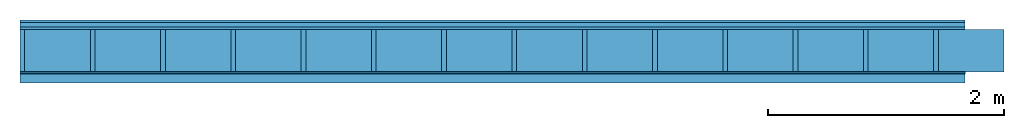
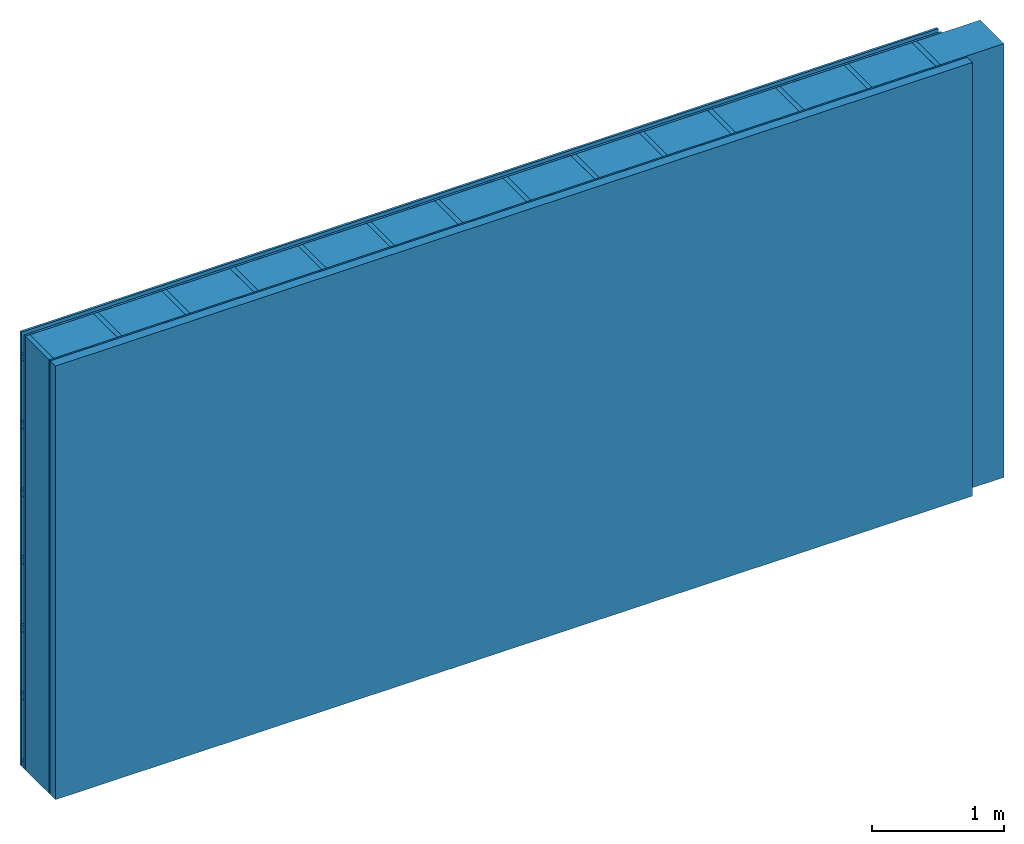
# One storey: 4 plates, 3 members, 1 element without a shape of its own.
"""IFC4 building model written with IfcOpenShell, lengths in metres."""

from ifc_helpers import new_model, si_unit, derived_unit, direction, frame, frame_2d, origin, origin_with_axes, place, context, project, spatial, rectangle, extrude, material, layer, layer_set, type_object, element, aggregate, save


model = new_model("IFC4")

# Units and contexts
plan_context = context("Plan", 3, precision=1e-05, world=origin(), true_north=direction((0.0, 1.0)))
model_context = context("Model", 3, precision=1e-05, world=origin(), true_north=direction((0.0, 1.0)))
ifc_project = project(units=[si_unit("LENGTHUNIT", "METRE"), derived_unit("SOUNDPRESSUREUNIT", [(si_unit("PRESSUREUNIT", "PASCAL", prefix="MICRO"), 0)]), si_unit("ENERGYUNIT", "JOULE", prefix="MEGA"), si_unit("MASSUNIT", "GRAM", prefix="KILO"), derived_unit("THERMALTRANSMITTANCEUNIT", [(si_unit("POWERUNIT", "WATT"), 1), (si_unit("AREAUNIT", "SQUARE_METRE"), -1), (si_unit("THERMODYNAMICTEMPERATUREUNIT", "KELVIN"), -1)]), derived_unit("AREADENSITYUNIT", [(si_unit("MASSUNIT", "GRAM", prefix="KILO"), 1), (si_unit("AREAUNIT", "SQUARE_METRE"), -1)]), derived_unit("USERDEFINED", [(si_unit("ENERGYUNIT", "JOULE", prefix="MEGA"), 1), (si_unit("AREAUNIT", "SQUARE_METRE"), -1)])], contexts=[plan_context, model_context])

# Site, building, storey
site = spatial("IfcSite", under=ifc_project)
building_placement = place(None, origin())
building = spatial("IfcBuilding", under=site, at=building_placement)
storey_placement = place(building_placement, origin())
storey = spatial("IfcBuildingStorey", under=building, at=storey_placement)

# Wall, members, plates
ifc_material_1 = material(Name="Wood cladding horizontal, closed")
ifc_layer_1 = layer(ifc_material_1, 0.02, Name="Cover 1st layer")
ifc_layer_2 = layer(None, 0.04, Name="Battens / profiles (ventilation)")
ifc_material_2 = material(Category="10.009")
ifc_layer_3 = layer(ifc_material_2, 0.02, Name="outside 1st layer")
ifc_material_3 = material(Name="of the art")
ifc_layer_4 = layer(ifc_material_3, 0.0, Name="Bond")
ifc_layer_5 = layer(None, 0.36, Name="Support")
ifc_layer_6 = layer(ifc_material_3, 0.0, Name="Bond")
ifc_material_4 = material(Name="OSB panel", Category="07.013")
ifc_layer_7 = layer(ifc_material_4, 0.015, Name="1st layer")
ifc_material_5 = material(Name="Solid timber panel")
ifc_layer_8 = layer(ifc_material_5, 0.08, Name="Covering 1st layer")
ifc_layer_set = layer_set([ifc_layer_1, ifc_layer_2, ifc_layer_3, ifc_layer_4, ifc_layer_5, ifc_layer_6, ifc_layer_7, ifc_layer_8])
wall_type = type_object("IfcWallType", Name="D0958", PredefinedType="NOTDEFINED", material=ifc_layer_set)
wall_placement = place(None, frame((0.0, 0.0, 0.0), z_axis=(0.0, -1.0, 0.0), x_axis=(1.0, 0.0, 0.0)))
wall = element("IfcWall", 1, at=wall_placement, inside=storey, type_object=wall_type, material=ifc_layer_set, Name="Wall #1")
ifc_material_6 = material()
member_1_placement = place(wall_placement, origin())
member_1 = element("IfcMember", 2, at=member_1_placement, material=ifc_material_6, Name="Battens / profiles (ventilation)", context=plan_context, shape_type="SweptSolid", body=[
    extrude(rectangle(XDim=0.06, YDim=0.04, at=frame_2d((0.03, 0.02), x_axis=(1.0, 0.0))), frame((0.0, 0.0, 0.02), z_axis=(1.0, 0.0, 0.0), x_axis=(0.0, 1.0, 0.0)), (0.0, 0.0, 1.0), 8.0),
    extrude(rectangle(XDim=0.06, YDim=0.04, at=frame_2d((0.03, 0.02), x_axis=(1.0, 0.0))), frame((0.0, 0.625, 0.02), z_axis=(1.0, 0.0, 0.0), x_axis=(0.0, 1.0, 0.0)), (0.0, 0.0, 1.0), 8.0),
    extrude(rectangle(XDim=0.06, YDim=0.04, at=frame_2d((0.03, 0.02), x_axis=(1.0, 0.0))), frame((0.0, 1.25, 0.02), z_axis=(1.0, 0.0, 0.0), x_axis=(0.0, 1.0, 0.0)), (0.0, 0.0, 1.0), 8.0),
    extrude(rectangle(XDim=0.06, YDim=0.04, at=frame_2d((0.03, 0.02), x_axis=(1.0, 0.0))), frame((0.0, 1.875, 0.02), z_axis=(1.0, 0.0, 0.0), x_axis=(0.0, 1.0, 0.0)), (0.0, 0.0, 1.0), 8.0),
    extrude(rectangle(XDim=0.06, YDim=0.04, at=frame_2d((0.03, 0.02), x_axis=(1.0, 0.0))), frame((0.0, 2.5, 0.02), z_axis=(1.0, 0.0, 0.0), x_axis=(0.0, 1.0, 0.0)), (0.0, 0.0, 1.0), 8.0),
    extrude(rectangle(XDim=0.06, YDim=0.04, at=frame_2d((0.03, 0.02), x_axis=(1.0, 0.0))), frame((0.0, 3.125, 0.02), z_axis=(1.0, 0.0, 0.0), x_axis=(0.0, 1.0, 0.0)), (0.0, 0.0, 1.0), 8.0),
    extrude(rectangle(XDim=0.06, YDim=0.04, at=frame_2d((0.03, 0.02), x_axis=(1.0, 0.0))), frame((0.0, 3.75, 0.02), z_axis=(1.0, 0.0, 0.0), x_axis=(0.0, 1.0, 0.0)), (0.0, 0.0, 1.0), 8.0),
])
ifc_material_7 = material()
member_2_placement = place(wall_placement, origin())
member_2 = element("IfcMember", 3, at=member_2_placement, material=ifc_material_7, Name="Support", context=plan_context, shape_type="SweptSolid", body=[
    extrude(rectangle(XDim=0.04, YDim=0.36, at=frame_2d((0.02, 0.18), x_axis=(1.0, 0.0))), frame((0.0, 4.0, 0.08), z_axis=(0.0, -1.0, 0.0), x_axis=(1.0, 0.0, 0.0)), (0.0, 0.0, 1.0), 4.0),
    extrude(rectangle(XDim=0.04, YDim=0.36, at=frame_2d((0.02, 0.18), x_axis=(1.0, 0.0))), frame((0.595, 4.0, 0.08), z_axis=(0.0, -1.0, 0.0), x_axis=(1.0, 0.0, 0.0)), (0.0, 0.0, 1.0), 4.0),
    extrude(rectangle(XDim=0.04, YDim=0.36, at=frame_2d((0.02, 0.18), x_axis=(1.0, 0.0))), frame((1.19, 4.0, 0.08), z_axis=(0.0, -1.0, 0.0), x_axis=(1.0, 0.0, 0.0)), (0.0, 0.0, 1.0), 4.0),
    extrude(rectangle(XDim=0.04, YDim=0.36, at=frame_2d((0.02, 0.18), x_axis=(1.0, 0.0))), frame((1.785, 4.0, 0.08), z_axis=(0.0, -1.0, 0.0), x_axis=(1.0, 0.0, 0.0)), (0.0, 0.0, 1.0), 4.0),
    extrude(rectangle(XDim=0.04, YDim=0.36, at=frame_2d((0.02, 0.18), x_axis=(1.0, 0.0))), frame((2.38, 4.0, 0.08), z_axis=(0.0, -1.0, 0.0), x_axis=(1.0, 0.0, 0.0)), (0.0, 0.0, 1.0), 4.0),
    extrude(rectangle(XDim=0.04, YDim=0.36, at=frame_2d((0.02, 0.18), x_axis=(1.0, 0.0))), frame((2.975, 4.0, 0.08), z_axis=(0.0, -1.0, 0.0), x_axis=(1.0, 0.0, 0.0)), (0.0, 0.0, 1.0), 4.0),
    extrude(rectangle(XDim=0.04, YDim=0.36, at=frame_2d((0.02, 0.18), x_axis=(1.0, 0.0))), frame((3.57, 4.0, 0.08), z_axis=(0.0, -1.0, 0.0), x_axis=(1.0, 0.0, 0.0)), (0.0, 0.0, 1.0), 4.0),
    extrude(rectangle(XDim=0.04, YDim=0.36, at=frame_2d((0.02, 0.18), x_axis=(1.0, 0.0))), frame((4.165, 4.0, 0.08), z_axis=(0.0, -1.0, 0.0), x_axis=(1.0, 0.0, 0.0)), (0.0, 0.0, 1.0), 4.0),
    extrude(rectangle(XDim=0.04, YDim=0.36, at=frame_2d((0.02, 0.18), x_axis=(1.0, 0.0))), frame((4.76, 4.0, 0.08), z_axis=(0.0, -1.0, 0.0), x_axis=(1.0, 0.0, 0.0)), (0.0, 0.0, 1.0), 4.0),
    extrude(rectangle(XDim=0.04, YDim=0.36, at=frame_2d((0.02, 0.18), x_axis=(1.0, 0.0))), frame((5.355, 4.0, 0.08), z_axis=(0.0, -1.0, 0.0), x_axis=(1.0, 0.0, 0.0)), (0.0, 0.0, 1.0), 4.0),
    extrude(rectangle(XDim=0.04, YDim=0.36, at=frame_2d((0.02, 0.18), x_axis=(1.0, 0.0))), frame((5.95, 4.0, 0.08), z_axis=(0.0, -1.0, 0.0), x_axis=(1.0, 0.0, 0.0)), (0.0, 0.0, 1.0), 4.0),
    extrude(rectangle(XDim=0.04, YDim=0.36, at=frame_2d((0.02, 0.18), x_axis=(1.0, 0.0))), frame((6.545, 4.0, 0.08), z_axis=(0.0, -1.0, 0.0), x_axis=(1.0, 0.0, 0.0)), (0.0, 0.0, 1.0), 4.0),
    extrude(rectangle(XDim=0.04, YDim=0.36, at=frame_2d((0.02, 0.18), x_axis=(1.0, 0.0))), frame((7.14, 4.0, 0.08), z_axis=(0.0, -1.0, 0.0), x_axis=(1.0, 0.0, 0.0)), (0.0, 0.0, 1.0), 4.0),
    extrude(rectangle(XDim=0.04, YDim=0.36, at=frame_2d((0.02, 0.18), x_axis=(1.0, 0.0))), frame((7.735, 4.0, 0.08), z_axis=(0.0, -1.0, 0.0), x_axis=(1.0, 0.0, 0.0)), (0.0, 0.0, 1.0), 4.0),
])
ifc_material_8 = material()
member_3_placement = place(wall_placement, origin())
member_3 = element("IfcMember", 4, at=member_3_placement, material=ifc_material_8, Name="Cavity", context=plan_context, shape_type="SweptSolid", body=[
    extrude(rectangle(XDim=0.555, YDim=0.36, at=frame_2d((0.2775, 0.18), x_axis=(1.0, 0.0))), frame((0.04, 4.0, 0.08), z_axis=(0.0, -1.0, 0.0), x_axis=(1.0, 0.0, 0.0)), (0.0, 0.0, 1.0), 4.0),
    extrude(rectangle(XDim=0.555, YDim=0.36, at=frame_2d((0.2775, 0.18), x_axis=(1.0, 0.0))), frame((0.635, 4.0, 0.08), z_axis=(0.0, -1.0, 0.0), x_axis=(1.0, 0.0, 0.0)), (0.0, 0.0, 1.0), 4.0),
    extrude(rectangle(XDim=0.555, YDim=0.36, at=frame_2d((0.2775, 0.18), x_axis=(1.0, 0.0))), frame((1.23, 4.0, 0.08), z_axis=(0.0, -1.0, 0.0), x_axis=(1.0, 0.0, 0.0)), (0.0, 0.0, 1.0), 4.0),
    extrude(rectangle(XDim=0.555, YDim=0.36, at=frame_2d((0.2775, 0.18), x_axis=(1.0, 0.0))), frame((1.825, 4.0, 0.08), z_axis=(0.0, -1.0, 0.0), x_axis=(1.0, 0.0, 0.0)), (0.0, 0.0, 1.0), 4.0),
    extrude(rectangle(XDim=0.555, YDim=0.36, at=frame_2d((0.2775, 0.18), x_axis=(1.0, 0.0))), frame((2.42, 4.0, 0.08), z_axis=(0.0, -1.0, 0.0), x_axis=(1.0, 0.0, 0.0)), (0.0, 0.0, 1.0), 4.0),
    extrude(rectangle(XDim=0.555, YDim=0.36, at=frame_2d((0.2775, 0.18), x_axis=(1.0, 0.0))), frame((3.015, 4.0, 0.08), z_axis=(0.0, -1.0, 0.0), x_axis=(1.0, 0.0, 0.0)), (0.0, 0.0, 1.0), 4.0),
    extrude(rectangle(XDim=0.555, YDim=0.36, at=frame_2d((0.2775, 0.18), x_axis=(1.0, 0.0))), frame((3.61, 4.0, 0.08), z_axis=(0.0, -1.0, 0.0), x_axis=(1.0, 0.0, 0.0)), (0.0, 0.0, 1.0), 4.0),
    extrude(rectangle(XDim=0.555, YDim=0.36, at=frame_2d((0.2775, 0.18), x_axis=(1.0, 0.0))), frame((4.205, 4.0, 0.08), z_axis=(0.0, -1.0, 0.0), x_axis=(1.0, 0.0, 0.0)), (0.0, 0.0, 1.0), 4.0),
    extrude(rectangle(XDim=0.555, YDim=0.36, at=frame_2d((0.2775, 0.18), x_axis=(1.0, 0.0))), frame((4.8, 4.0, 0.08), z_axis=(0.0, -1.0, 0.0), x_axis=(1.0, 0.0, 0.0)), (0.0, 0.0, 1.0), 4.0),
    extrude(rectangle(XDim=0.555, YDim=0.36, at=frame_2d((0.2775, 0.18), x_axis=(1.0, 0.0))), frame((5.395, 4.0, 0.08), z_axis=(0.0, -1.0, 0.0), x_axis=(1.0, 0.0, 0.0)), (0.0, 0.0, 1.0), 4.0),
    extrude(rectangle(XDim=0.555, YDim=0.36, at=frame_2d((0.2775, 0.18), x_axis=(1.0, 0.0))), frame((5.99, 4.0, 0.08), z_axis=(0.0, -1.0, 0.0), x_axis=(1.0, 0.0, 0.0)), (0.0, 0.0, 1.0), 4.0),
    extrude(rectangle(XDim=0.555, YDim=0.36, at=frame_2d((0.2775, 0.18), x_axis=(1.0, 0.0))), frame((6.585, 4.0, 0.08), z_axis=(0.0, -1.0, 0.0), x_axis=(1.0, 0.0, 0.0)), (0.0, 0.0, 1.0), 4.0),
    extrude(rectangle(XDim=0.555, YDim=0.36, at=frame_2d((0.2775, 0.18), x_axis=(1.0, 0.0))), frame((7.18, 4.0, 0.08), z_axis=(0.0, -1.0, 0.0), x_axis=(1.0, 0.0, 0.0)), (0.0, 0.0, 1.0), 4.0),
    extrude(rectangle(XDim=0.555, YDim=0.36, at=frame_2d((0.2775, 0.18), x_axis=(1.0, 0.0))), frame((7.775, 4.0, 0.08), z_axis=(0.0, -1.0, 0.0), x_axis=(1.0, 0.0, 0.0)), (0.0, 0.0, 1.0), 4.0),
])
plate_1_placement = place(wall_placement, origin())
plate_1 = element("IfcPlate", 5, at=plate_1_placement, material=ifc_material_1, Name="Cover 1st layer", context=plan_context, shape_type="SweptSolid", body=[
    extrude(rectangle(XDim=8.0, YDim=4.0, at=frame_2d((4.0, 2.0), x_axis=(1.0, 0.0))), origin_with_axes(), (0.0, 0.0, 1.0), 0.02),
])
plate_2_placement = place(wall_placement, origin())
plate_2 = element("IfcPlate", 6, at=plate_2_placement, material=ifc_material_2, Name="outside 1st layer", context=plan_context, shape_type="SweptSolid", body=[
    extrude(rectangle(XDim=8.0, YDim=4.0, at=frame_2d((4.0, 2.0), x_axis=(1.0, 0.0))), frame((0.0, 0.0, 0.06), z_axis=(0.0, 0.0, 1.0), x_axis=(1.0, 0.0, 0.0)), (0.0, 0.0, 1.0), 0.02),
])
plate_3_placement = place(wall_placement, origin())
plate_3 = element("IfcPlate", 7, at=plate_3_placement, material=ifc_material_4, Name="1st layer", context=plan_context, shape_type="SweptSolid", body=[
    extrude(rectangle(XDim=8.0, YDim=4.0, at=frame_2d((4.0, 2.0), x_axis=(1.0, 0.0))), frame((0.0, 0.0, 0.44), z_axis=(0.0, 0.0, 1.0), x_axis=(1.0, 0.0, 0.0)), (0.0, 0.0, 1.0), 0.015),
])
plate_4_placement = place(wall_placement, origin())
plate_4 = element("IfcPlate", 8, at=plate_4_placement, material=ifc_material_5, Name="Covering 1st layer", context=plan_context, shape_type="SweptSolid", body=[
    extrude(rectangle(XDim=8.0, YDim=4.0, at=frame_2d((4.0, 2.0), x_axis=(1.0, 0.0))), frame((0.0, 0.0, 0.455), z_axis=(0.0, 0.0, 1.0), x_axis=(1.0, 0.0, 0.0)), (0.0, 0.0, 1.0), 0.08),
])
aggregate(wall, [plate_1, member_1, plate_2, member_2, member_3, plate_3, plate_4])

save(model, "model.ifc")
